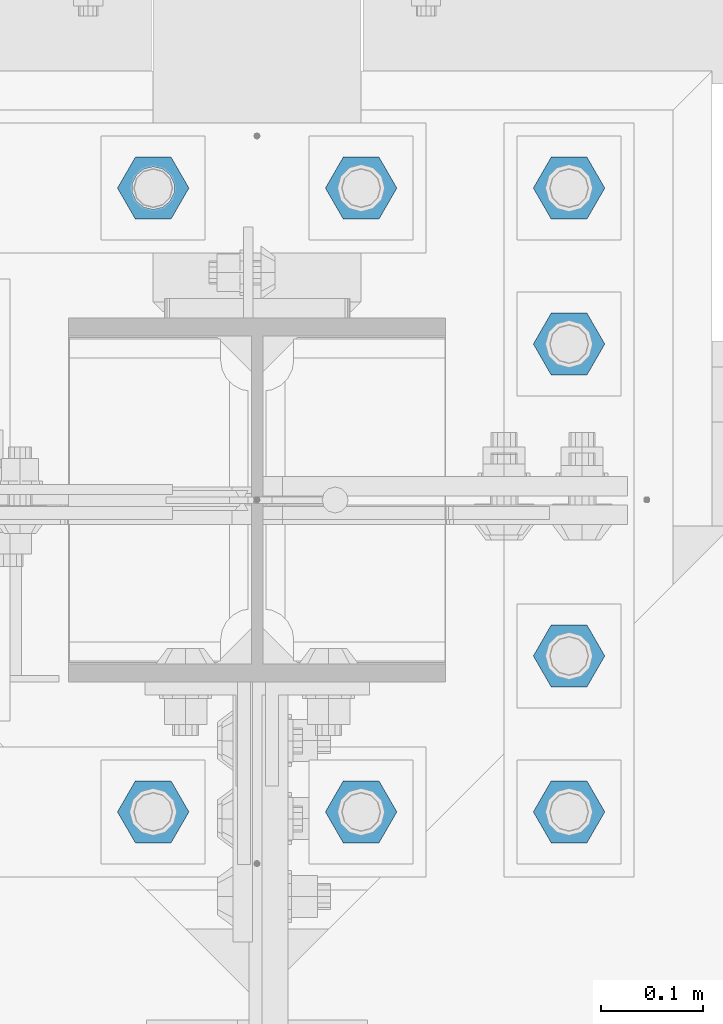
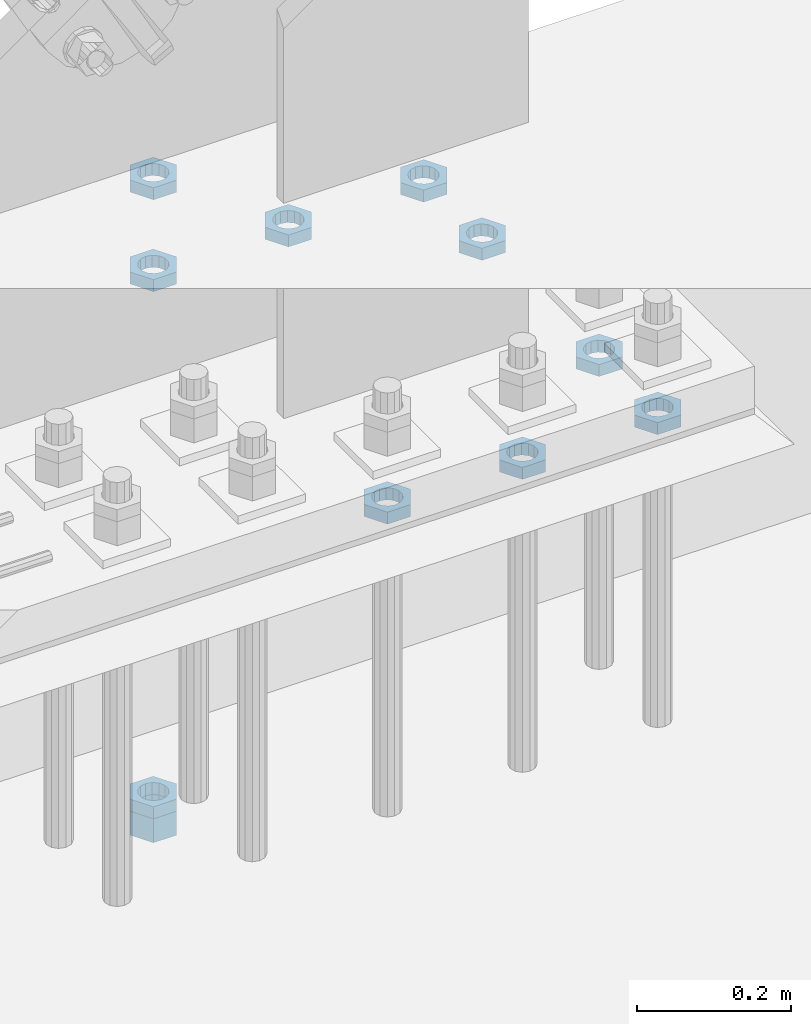
# One storey, part 2896 of 3843: 11 beams, 1 element without a shape of its own.
"""IFC2X3 building model written with IfcOpenShell, lengths in millimetres."""

from ifc_helpers import new_model, si_unit, frame, origin_with_axes, place, context, subcontext, project, spatial, faceted_brep, material, type_object, element, aggregate, save


model = new_model("IFC2X3")

# Units and contexts
model_context = context("Model", 3, precision=1e-05, world=origin_with_axes())
body_context = subcontext(model_context, "Body", "Model", "MODEL_VIEW")
ifc_project = project(units=[si_unit("LENGTHUNIT", "METRE", prefix="MILLI"), si_unit("AREAUNIT", "SQUARE_METRE"), si_unit("VOLUMEUNIT", "CUBIC_METRE"), si_unit("MASSUNIT", "GRAM", prefix="KILO"), si_unit("TIMEUNIT", "SECOND"), si_unit("PLANEANGLEUNIT", "RADIAN"), si_unit("SOLIDANGLEUNIT", "STERADIAN"), si_unit("THERMODYNAMICTEMPERATUREUNIT", "DEGREE_CELSIUS"), si_unit("LUMINOUSINTENSITYUNIT", "LUMEN")], contexts=[model_context])

# Site, building, storey
site_placement = place(None, origin_with_axes())
site = spatial("IfcSite", under=ifc_project, at=site_placement, CompositionType="ELEMENT")
building_placement = place(site_placement, origin_with_axes())
building = spatial("IfcBuilding", under=site, at=building_placement, Name="Undefined", CompositionType="ELEMENT")
storey_placement = place(building_placement, origin_with_axes())
storey = spatial("IfcBuildingStorey", under=building, at=storey_placement, Name="Undefined", CompositionType="ELEMENT", Elevation=0.0)

# Assembly, beams
assembly_placement = place(storey_placement, origin_with_axes())
assembly = element("IfcElementAssembly", 1, at=assembly_placement, inside=storey, Name="TEMPLATE", AssemblyPlace="NOTDEFINED", PredefinedType="RIGID_FRAME")
ifc_material = material(Name="STEEL/A572-50")
beam_type_1 = type_object("IfcBeamType", Name="1-1/2_HEAVY_HEX_NUT", PredefinedType="NOTDEFINED")
beam_1_placement = place(assembly_placement, frame((62534.8, 92519.5, 29203.6500015259), z_axis=(0.0, -1.0, 0.0), x_axis=(0.0, 0.0, -1.0)))
beam_1 = element("IfcBeam", 2, at=beam_1_placement, type_object=beam_type_1, material=ifc_material, Name="NUT", ObjectType="1-1/2_HEAVY_HEX_NUT", context=body_context, shape_type="Brep", body=[
    faceted_brep([(0.0, -34.9199981689453, 0.0), (0.0, -17.4599990844727, -30.25), (38.0999999999985, -17.4599990844727, -30.25), (38.0999999999985, -34.9199981689453, 0.0), (0.0, 17.4599990844727, -30.25), (38.0999999999985, 17.4599990844727, -30.25), (0.0, 34.9199981689453, 0.0), (38.0999999999985, 34.9199981689453, 0.0), (0.0, 17.4599990844727, 30.25), (38.0999999999985, 17.4599990844727, 30.25), (0.0, -17.4599990844727, 30.25), (38.0999999999985, -17.4599990844727, 30.25), (0.0, 0.0, 20.6399993896484), (0.0, 8.9553601105581, 18.5959968835959), (38.0999999999985, 8.9553601105581, 18.5959968835959), (38.0999999999985, 0.0, 20.6399993896484), (0.0, 16.1370013209525, 12.8688291298167), (38.0999999999985, 16.1370013209525, 12.8688291298167), (0.0, 20.1225115123816, 4.59283194104501), (38.0999999999985, 20.1225115123816, 4.59283194104501), (0.0, 20.1225115123816, -4.59283194104501), (38.0999999999985, 20.1225115123816, -4.59283194104501), (0.0, 16.1370013209525, -12.8688291298167), (38.0999999999985, 16.1370013209525, -12.8688291298167), (0.0, 8.9553601105581, -18.5959968835959), (38.0999999999985, 8.9553601105581, -18.5959968835959), (0.0, 0.0, -20.6399993896484), (38.0999999999985, 0.0, -20.6399993896484), (0.0, -8.9553601105581, -18.5959968835959), (38.0999999999985, -8.9553601105581, -18.5959968835959), (0.0, -16.1370013209525, -12.8688291298167), (38.0999999999985, -16.1370013209525, -12.8688291298167), (0.0, -20.1225115123816, -4.59283194104501), (38.0999999999985, -20.1225115123816, -4.59283194104501), (0.0, -20.1225115123816, 4.59283194104501), (38.0999999999985, -20.1225115123816, 4.59283194104501), (0.0, -16.1370013209525, 12.8688291298167), (38.0999999999985, -16.1370013209525, 12.8688291298167), (0.0, -8.9553601105581, 18.5959968835959), (38.0999999999985, -8.9553601105581, 18.5959968835959)], [[[0, 1, 2, 3]], [[1, 4, 5, 2]], [[4, 6, 7, 5]], [[6, 8, 9, 7]], [[8, 10, 11, 9]], [[10, 0, 3, 11]], [[12, 13, 14, 15]], [[13, 16, 17, 14]], [[16, 18, 19, 17]], [[18, 20, 21, 19]], [[20, 22, 23, 21]], [[22, 24, 25, 23]], [[24, 26, 27, 25]], [[26, 28, 29, 27]], [[28, 30, 31, 29]], [[30, 32, 33, 31]], [[32, 34, 35, 33]], [[34, 36, 37, 35]], [[36, 38, 39, 37]], [[38, 12, 15, 39]], [[5, 7, 9, 11, 3, 2], [17, 19, 21, 23, 25, 27, 29, 31, 33, 35, 37, 39, 15, 14]], [[10, 8, 6, 4, 1, 0], [38, 36, 34, 32, 30, 28, 26, 24, 22, 20, 18, 16, 13, 12]]]),
])
beam_type_2 = type_object("IfcBeamType", Name="1-1/2_HALF_NUT", PredefinedType="NOTDEFINED")
beam_2_placement = place(assembly_placement, frame((62534.8, 92519.5, 30060.9), z_axis=(0.0, -1.0, 0.0), x_axis=(0.0, 0.0, -1.0)))
beam_2 = element("IfcBeam", 3, at=beam_2_placement, type_object=beam_type_2, material=ifc_material, Name="NUT", ObjectType="1-1/2_HALF_NUT", context=body_context, shape_type="Brep", body=[
    faceted_brep([(0.0, -34.9199981689453, 0.0), (0.0, -17.4599990844727, -30.25), (19.0500000000029, -17.4599990844727, -30.25), (19.0500000000029, -34.9199981689453, 0.0), (0.0, 17.4599990844727, -30.25), (19.0500000000029, 17.4599990844727, -30.25), (0.0, 34.9199981689453, 0.0), (19.0500000000029, 34.9199981689453, 0.0), (0.0, 17.4599990844727, 30.25), (19.0500000000029, 17.4599990844727, 30.25), (0.0, -17.4599990844727, 30.25), (19.0500000000029, -17.4599990844727, 30.25), (0.0, 0.0, 20.6399993896484), (0.0, 8.9553601105581, 18.5959968835959), (19.0500000000029, 8.95536011056538, 18.5959968835959), (19.0500000000029, 0.0, 20.6399993896484), (0.0, 16.1370013209525, 12.8688291298167), (19.0500000000029, 16.1370013209489, 12.8688291298167), (0.0, 20.1225115123816, 4.59283194104501), (19.0500000000029, 20.1225115123852, 4.59283194104501), (0.0, 20.1225115123816, -4.59283194104501), (19.0500000000029, 20.1225115123852, -4.59283194104501), (0.0, 16.1370013209525, -12.8688291298167), (19.0500000000029, 16.1370013209489, -12.8688291298167), (0.0, 8.9553601105581, -18.5959968835959), (19.0500000000029, 8.95536011056538, -18.5959968835959), (0.0, 0.0, -20.6399993896484), (19.0500000000029, 0.0, -20.6399993896484), (0.0, -8.9553601105581, -18.5959968835959), (19.0500000000029, -8.95536011056538, -18.5959968835959), (0.0, -16.1370013209525, -12.8688291298167), (19.0500000000029, -16.1370013209489, -12.8688291298167), (0.0, -20.1225115123816, -4.59283194104501), (19.0500000000029, -20.1225115123852, -4.59283194104501), (0.0, -20.1225115123816, 4.59283194104501), (19.0500000000029, -20.1225115123852, 4.59283194104501), (0.0, -16.1370013209525, 12.8688291298167), (19.0500000000029, -16.1370013209489, 12.8688291298167), (0.0, -8.9553601105581, 18.5959968835959), (19.0500000000029, -8.95536011056538, 18.5959968835959)], [[[0, 1, 2, 3]], [[1, 4, 5, 2]], [[4, 6, 7, 5]], [[6, 8, 9, 7]], [[8, 10, 11, 9]], [[10, 0, 3, 11]], [[12, 13, 14, 15]], [[13, 16, 17, 14]], [[16, 18, 19, 17]], [[18, 20, 21, 19]], [[20, 22, 23, 21]], [[22, 24, 25, 23]], [[24, 26, 27, 25]], [[26, 28, 29, 27]], [[28, 30, 31, 29]], [[30, 32, 33, 31]], [[32, 34, 35, 33]], [[34, 36, 37, 35]], [[36, 38, 39, 37]], [[38, 12, 15, 39]], [[5, 7, 9, 11, 3, 2], [17, 19, 21, 23, 25, 27, 29, 31, 33, 35, 37, 39, 15, 14]], [[10, 8, 6, 4, 1, 0], [38, 36, 34, 32, 30, 28, 26, 24, 22, 20, 18, 16, 13, 12]]]),
])
beam_3_placement = place(assembly_placement, frame((62738.0, 92519.5, 30060.9), z_axis=(0.0, 1.0, 0.0), x_axis=(0.0, 0.0, -1.0)))
beam_3 = element("IfcBeam", 4, at=beam_3_placement, type_object=beam_type_2, material=ifc_material, Name="NUT", ObjectType="1-1/2_HALF_NUT", context=body_context, shape_type="Brep", body=[
    faceted_brep([(0.0, -34.9199981689453, 0.0), (0.0, -17.4599990844727, -30.25), (19.0500000000029, -17.4599990844727, -30.25), (19.0500000000029, -34.9199981689453, 0.0), (0.0, 17.4599990844727, -30.25), (19.0500000000029, 17.4599990844727, -30.25), (0.0, 34.9199981689453, 0.0), (19.0500000000029, 34.9199981689453, 0.0), (0.0, 17.4599990844727, 30.25), (19.0500000000029, 17.4599990844727, 30.25), (0.0, -17.4599990844727, 30.25), (19.0500000000029, -17.4599990844727, 30.25), (0.0, 0.0, 20.6399993896484), (0.0, 8.9553601105581, 18.5959968835959), (19.0500000000029, 8.95536011056538, 18.5959968835959), (19.0500000000029, 0.0, 20.6399993896484), (0.0, 16.1370013209525, 12.8688291298167), (19.0500000000029, 16.1370013209489, 12.8688291298167), (0.0, 20.1225115123816, 4.59283194104501), (19.0500000000029, 20.1225115123852, 4.59283194104501), (0.0, 20.1225115123816, -4.59283194104501), (19.0500000000029, 20.1225115123852, -4.59283194104501), (0.0, 16.1370013209525, -12.8688291298167), (19.0500000000029, 16.1370013209489, -12.8688291298167), (0.0, 8.9553601105581, -18.5959968835959), (19.0500000000029, 8.95536011056538, -18.5959968835959), (0.0, 0.0, -20.6399993896484), (19.0500000000029, 0.0, -20.6399993896484), (0.0, -8.9553601105581, -18.5959968835959), (19.0500000000029, -8.95536011056538, -18.5959968835959), (0.0, -16.1370013209525, -12.8688291298167), (19.0500000000029, -16.1370013209489, -12.8688291298167), (0.0, -20.1225115123816, -4.59283194104501), (19.0500000000029, -20.1225115123852, -4.59283194104501), (0.0, -20.1225115123816, 4.59283194104501), (19.0500000000029, -20.1225115123852, 4.59283194104501), (0.0, -16.1370013209525, 12.8688291298167), (19.0500000000029, -16.1370013209489, 12.8688291298167), (0.0, -8.9553601105581, 18.5959968835959), (19.0500000000029, -8.95536011056538, 18.5959968835959)], [[[0, 1, 2, 3]], [[1, 4, 5, 2]], [[4, 6, 7, 5]], [[6, 8, 9, 7]], [[8, 10, 11, 9]], [[10, 0, 3, 11]], [[12, 13, 14, 15]], [[13, 16, 17, 14]], [[16, 18, 19, 17]], [[18, 20, 21, 19]], [[20, 22, 23, 21]], [[22, 24, 25, 23]], [[24, 26, 27, 25]], [[26, 28, 29, 27]], [[28, 30, 31, 29]], [[30, 32, 33, 31]], [[32, 34, 35, 33]], [[34, 36, 37, 35]], [[36, 38, 39, 37]], [[38, 12, 15, 39]], [[5, 7, 9, 11, 3, 2], [17, 19, 21, 23, 25, 27, 29, 31, 33, 35, 37, 39, 15, 14]], [[10, 8, 6, 4, 1, 0], [38, 36, 34, 32, 30, 28, 26, 24, 22, 20, 18, 16, 13, 12]]]),
])
beam_4_placement = place(assembly_placement, frame((62534.8, 91909.9, 30060.9), z_axis=(0.0, -1.0, 0.0), x_axis=(0.0, 0.0, -1.0)))
beam_4 = element("IfcBeam", 5, at=beam_4_placement, type_object=beam_type_2, material=ifc_material, Name="NUT", ObjectType="1-1/2_HALF_NUT", context=body_context, shape_type="Brep", body=[
    faceted_brep([(0.0, -34.9199981689453, 0.0), (0.0, -17.4599990844727, -30.25), (19.0500000000029, -17.4599990844727, -30.25), (19.0500000000029, -34.9199981689453, 0.0), (0.0, 17.4599990844727, -30.25), (19.0500000000029, 17.4599990844727, -30.25), (0.0, 34.9199981689453, 0.0), (19.0500000000029, 34.9199981689453, 0.0), (0.0, 17.4599990844727, 30.25), (19.0500000000029, 17.4599990844727, 30.25), (0.0, -17.4599990844727, 30.25), (19.0500000000029, -17.4599990844727, 30.25), (0.0, 0.0, 20.6399993896484), (0.0, 8.9553601105581, 18.5959968835959), (19.0500000000029, 8.95536011056538, 18.5959968835959), (19.0500000000029, 0.0, 20.6399993896484), (0.0, 16.1370013209525, 12.8688291298167), (19.0500000000029, 16.1370013209489, 12.8688291298167), (0.0, 20.1225115123816, 4.59283194104501), (19.0500000000029, 20.1225115123852, 4.59283194104501), (0.0, 20.1225115123816, -4.59283194104501), (19.0500000000029, 20.1225115123852, -4.59283194104501), (0.0, 16.1370013209525, -12.8688291298167), (19.0500000000029, 16.1370013209489, -12.8688291298167), (0.0, 8.9553601105581, -18.5959968835959), (19.0500000000029, 8.95536011056538, -18.5959968835959), (0.0, 0.0, -20.6399993896484), (19.0500000000029, 0.0, -20.6399993896484), (0.0, -8.9553601105581, -18.5959968835959), (19.0500000000029, -8.95536011056538, -18.5959968835959), (0.0, -16.1370013209525, -12.8688291298167), (19.0500000000029, -16.1370013209489, -12.8688291298167), (0.0, -20.1225115123816, -4.59283194104501), (19.0500000000029, -20.1225115123852, -4.59283194104501), (0.0, -20.1225115123816, 4.59283194104501), (19.0500000000029, -20.1225115123852, 4.59283194104501), (0.0, -16.1370013209525, 12.8688291298167), (19.0500000000029, -16.1370013209489, 12.8688291298167), (0.0, -8.9553601105581, 18.5959968835959), (19.0500000000029, -8.95536011056538, 18.5959968835959)], [[[0, 1, 2, 3]], [[1, 4, 5, 2]], [[4, 6, 7, 5]], [[6, 8, 9, 7]], [[8, 10, 11, 9]], [[10, 0, 3, 11]], [[12, 13, 14, 15]], [[13, 16, 17, 14]], [[16, 18, 19, 17]], [[18, 20, 21, 19]], [[20, 22, 23, 21]], [[22, 24, 25, 23]], [[24, 26, 27, 25]], [[26, 28, 29, 27]], [[28, 30, 31, 29]], [[30, 32, 33, 31]], [[32, 34, 35, 33]], [[34, 36, 37, 35]], [[36, 38, 39, 37]], [[38, 12, 15, 39]], [[5, 7, 9, 11, 3, 2], [17, 19, 21, 23, 25, 27, 29, 31, 33, 35, 37, 39, 15, 14]], [[10, 8, 6, 4, 1, 0], [38, 36, 34, 32, 30, 28, 26, 24, 22, 20, 18, 16, 13, 12]]]),
])
beam_5_placement = place(assembly_placement, frame((62941.2, 92519.5, 30060.9), z_axis=(0.0, 1.0, 0.0), x_axis=(0.0, 0.0, -1.0)))
beam_5 = element("IfcBeam", 6, at=beam_5_placement, type_object=beam_type_2, material=ifc_material, Name="NUT", ObjectType="1-1/2_HALF_NUT", context=body_context, shape_type="Brep", body=[
    faceted_brep([(0.0, -34.9199981689453, 0.0), (0.0, -17.4599990844727, -30.25), (19.0500000000029, -17.4599990844727, -30.25), (19.0500000000029, -34.9199981689453, 0.0), (0.0, 17.4599990844727, -30.25), (19.0500000000029, 17.4599990844727, -30.25), (0.0, 34.9199981689453, 0.0), (19.0500000000029, 34.9199981689453, 0.0), (0.0, 17.4599990844727, 30.25), (19.0500000000029, 17.4599990844727, 30.25), (0.0, -17.4599990844727, 30.25), (19.0500000000029, -17.4599990844727, 30.25), (0.0, 0.0, 20.6399993896484), (0.0, 8.9553601105581, 18.5959968835959), (19.0500000000029, 8.95536011056538, 18.5959968835959), (19.0500000000029, 0.0, 20.6399993896484), (0.0, 16.1370013209525, 12.8688291298167), (19.0500000000029, 16.1370013209489, 12.8688291298167), (0.0, 20.1225115123816, 4.59283194104501), (19.0500000000029, 20.1225115123852, 4.59283194104501), (0.0, 20.1225115123816, -4.59283194104501), (19.0500000000029, 20.1225115123852, -4.59283194104501), (0.0, 16.1370013209525, -12.8688291298167), (19.0500000000029, 16.1370013209489, -12.8688291298167), (0.0, 8.9553601105581, -18.5959968835959), (19.0500000000029, 8.95536011056538, -18.5959968835959), (0.0, 0.0, -20.6399993896484), (19.0500000000029, 0.0, -20.6399993896484), (0.0, -8.9553601105581, -18.5959968835959), (19.0500000000029, -8.95536011056538, -18.5959968835959), (0.0, -16.1370013209525, -12.8688291298167), (19.0500000000029, -16.1370013209489, -12.8688291298167), (0.0, -20.1225115123816, -4.59283194104501), (19.0500000000029, -20.1225115123852, -4.59283194104501), (0.0, -20.1225115123816, 4.59283194104501), (19.0500000000029, -20.1225115123852, 4.59283194104501), (0.0, -16.1370013209525, 12.8688291298167), (19.0500000000029, -16.1370013209489, 12.8688291298167), (0.0, -8.9553601105581, 18.5959968835959), (19.0500000000029, -8.95536011056538, 18.5959968835959)], [[[0, 1, 2, 3]], [[1, 4, 5, 2]], [[4, 6, 7, 5]], [[6, 8, 9, 7]], [[8, 10, 11, 9]], [[10, 0, 3, 11]], [[12, 13, 14, 15]], [[13, 16, 17, 14]], [[16, 18, 19, 17]], [[18, 20, 21, 19]], [[20, 22, 23, 21]], [[22, 24, 25, 23]], [[24, 26, 27, 25]], [[26, 28, 29, 27]], [[28, 30, 31, 29]], [[30, 32, 33, 31]], [[32, 34, 35, 33]], [[34, 36, 37, 35]], [[36, 38, 39, 37]], [[38, 12, 15, 39]], [[5, 7, 9, 11, 3, 2], [17, 19, 21, 23, 25, 27, 29, 31, 33, 35, 37, 39, 15, 14]], [[10, 8, 6, 4, 1, 0], [38, 36, 34, 32, 30, 28, 26, 24, 22, 20, 18, 16, 13, 12]]]),
])
beam_6_placement = place(assembly_placement, frame((62941.2, 92367.1, 30060.9), z_axis=(0.0, 1.0, 0.0), x_axis=(0.0, 0.0, -1.0)))
beam_6 = element("IfcBeam", 7, at=beam_6_placement, type_object=beam_type_2, material=ifc_material, Name="NUT", ObjectType="1-1/2_HALF_NUT", context=body_context, shape_type="Brep", body=[
    faceted_brep([(0.0, -34.9199981689453, 0.0), (0.0, -17.4599990844727, -30.25), (19.0500000000029, -17.4599990844727, -30.25), (19.0500000000029, -34.9199981689453, 0.0), (0.0, 17.4599990844727, -30.25), (19.0500000000029, 17.4599990844727, -30.25), (0.0, 34.9199981689453, 0.0), (19.0500000000029, 34.9199981689453, 0.0), (0.0, 17.4599990844727, 30.25), (19.0500000000029, 17.4599990844727, 30.25), (0.0, -17.4599990844727, 30.25), (19.0500000000029, -17.4599990844727, 30.25), (0.0, 0.0, 20.6399993896484), (0.0, 8.9553601105581, 18.5959968835959), (19.0500000000029, 8.95536011056538, 18.5959968835959), (19.0500000000029, 0.0, 20.6399993896484), (0.0, 16.1370013209525, 12.8688291298167), (19.0500000000029, 16.1370013209489, 12.8688291298167), (0.0, 20.1225115123816, 4.59283194104501), (19.0500000000029, 20.1225115123852, 4.59283194104501), (0.0, 20.1225115123816, -4.59283194104501), (19.0500000000029, 20.1225115123852, -4.59283194104501), (0.0, 16.1370013209525, -12.8688291298167), (19.0500000000029, 16.1370013209489, -12.8688291298167), (0.0, 8.9553601105581, -18.5959968835959), (19.0500000000029, 8.95536011056538, -18.5959968835959), (0.0, 0.0, -20.6399993896484), (19.0500000000029, 0.0, -20.6399993896484), (0.0, -8.9553601105581, -18.5959968835959), (19.0500000000029, -8.95536011056538, -18.5959968835959), (0.0, -16.1370013209525, -12.8688291298167), (19.0500000000029, -16.1370013209489, -12.8688291298167), (0.0, -20.1225115123816, -4.59283194104501), (19.0500000000029, -20.1225115123852, -4.59283194104501), (0.0, -20.1225115123816, 4.59283194104501), (19.0500000000029, -20.1225115123852, 4.59283194104501), (0.0, -16.1370013209525, 12.8688291298167), (19.0500000000029, -16.1370013209489, 12.8688291298167), (0.0, -8.9553601105581, 18.5959968835959), (19.0500000000029, -8.95536011056538, 18.5959968835959)], [[[0, 1, 2, 3]], [[1, 4, 5, 2]], [[4, 6, 7, 5]], [[6, 8, 9, 7]], [[8, 10, 11, 9]], [[10, 0, 3, 11]], [[12, 13, 14, 15]], [[13, 16, 17, 14]], [[16, 18, 19, 17]], [[18, 20, 21, 19]], [[20, 22, 23, 21]], [[22, 24, 25, 23]], [[24, 26, 27, 25]], [[26, 28, 29, 27]], [[28, 30, 31, 29]], [[30, 32, 33, 31]], [[32, 34, 35, 33]], [[34, 36, 37, 35]], [[36, 38, 39, 37]], [[38, 12, 15, 39]], [[5, 7, 9, 11, 3, 2], [17, 19, 21, 23, 25, 27, 29, 31, 33, 35, 37, 39, 15, 14]], [[10, 8, 6, 4, 1, 0], [38, 36, 34, 32, 30, 28, 26, 24, 22, 20, 18, 16, 13, 12]]]),
])
beam_7_placement = place(assembly_placement, frame((62738.0, 91909.9, 30060.9), z_axis=(0.0, 1.0, 0.0), x_axis=(0.0, 0.0, -1.0)))
beam_7 = element("IfcBeam", 8, at=beam_7_placement, type_object=beam_type_2, material=ifc_material, Name="NUT", ObjectType="1-1/2_HALF_NUT", context=body_context, shape_type="Brep", body=[
    faceted_brep([(0.0, -34.9199981689453, 0.0), (0.0, -17.4599990844727, -30.25), (19.0500000000029, -17.4599990844727, -30.25), (19.0500000000029, -34.9199981689453, 0.0), (0.0, 17.4599990844727, -30.25), (19.0500000000029, 17.4599990844727, -30.25), (0.0, 34.9199981689453, 0.0), (19.0500000000029, 34.9199981689453, 0.0), (0.0, 17.4599990844727, 30.25), (19.0500000000029, 17.4599990844727, 30.25), (0.0, -17.4599990844727, 30.25), (19.0500000000029, -17.4599990844727, 30.25), (0.0, 0.0, 20.6399993896484), (0.0, 8.9553601105581, 18.5959968835959), (19.0500000000029, 8.95536011056538, 18.5959968835959), (19.0500000000029, 0.0, 20.6399993896484), (0.0, 16.1370013209525, 12.8688291298167), (19.0500000000029, 16.1370013209489, 12.8688291298167), (0.0, 20.1225115123816, 4.59283194104501), (19.0500000000029, 20.1225115123852, 4.59283194104501), (0.0, 20.1225115123816, -4.59283194104501), (19.0500000000029, 20.1225115123852, -4.59283194104501), (0.0, 16.1370013209525, -12.8688291298167), (19.0500000000029, 16.1370013209489, -12.8688291298167), (0.0, 8.9553601105581, -18.5959968835959), (19.0500000000029, 8.95536011056538, -18.5959968835959), (0.0, 0.0, -20.6399993896484), (19.0500000000029, 0.0, -20.6399993896484), (0.0, -8.9553601105581, -18.5959968835959), (19.0500000000029, -8.95536011056538, -18.5959968835959), (0.0, -16.1370013209525, -12.8688291298167), (19.0500000000029, -16.1370013209489, -12.8688291298167), (0.0, -20.1225115123816, -4.59283194104501), (19.0500000000029, -20.1225115123852, -4.59283194104501), (0.0, -20.1225115123816, 4.59283194104501), (19.0500000000029, -20.1225115123852, 4.59283194104501), (0.0, -16.1370013209525, 12.8688291298167), (19.0500000000029, -16.1370013209489, 12.8688291298167), (0.0, -8.9553601105581, 18.5959968835959), (19.0500000000029, -8.95536011056538, 18.5959968835959)], [[[0, 1, 2, 3]], [[1, 4, 5, 2]], [[4, 6, 7, 5]], [[6, 8, 9, 7]], [[8, 10, 11, 9]], [[10, 0, 3, 11]], [[12, 13, 14, 15]], [[13, 16, 17, 14]], [[16, 18, 19, 17]], [[18, 20, 21, 19]], [[20, 22, 23, 21]], [[22, 24, 25, 23]], [[24, 26, 27, 25]], [[26, 28, 29, 27]], [[28, 30, 31, 29]], [[30, 32, 33, 31]], [[32, 34, 35, 33]], [[34, 36, 37, 35]], [[36, 38, 39, 37]], [[38, 12, 15, 39]], [[5, 7, 9, 11, 3, 2], [17, 19, 21, 23, 25, 27, 29, 31, 33, 35, 37, 39, 15, 14]], [[10, 8, 6, 4, 1, 0], [38, 36, 34, 32, 30, 28, 26, 24, 22, 20, 18, 16, 13, 12]]]),
])
beam_8_placement = place(assembly_placement, frame((62941.2, 92062.3, 30060.9), z_axis=(0.0, 1.0, 0.0), x_axis=(0.0, 0.0, -1.0)))
beam_8 = element("IfcBeam", 9, at=beam_8_placement, type_object=beam_type_2, material=ifc_material, Name="NUT", ObjectType="1-1/2_HALF_NUT", context=body_context, shape_type="Brep", body=[
    faceted_brep([(0.0, -34.9199981689453, 0.0), (0.0, -17.4599990844727, -30.25), (19.0500000000029, -17.4599990844727, -30.25), (19.0500000000029, -34.9199981689453, 0.0), (0.0, 17.4599990844727, -30.25), (19.0500000000029, 17.4599990844727, -30.25), (0.0, 34.9199981689453, 0.0), (19.0500000000029, 34.9199981689453, 0.0), (0.0, 17.4599990844727, 30.25), (19.0500000000029, 17.4599990844727, 30.25), (0.0, -17.4599990844727, 30.25), (19.0500000000029, -17.4599990844727, 30.25), (0.0, 0.0, 20.6399993896484), (0.0, 8.9553601105581, 18.5959968835959), (19.0500000000029, 8.95536011056538, 18.5959968835959), (19.0500000000029, 0.0, 20.6399993896484), (0.0, 16.1370013209525, 12.8688291298167), (19.0500000000029, 16.1370013209489, 12.8688291298167), (0.0, 20.1225115123816, 4.59283194104501), (19.0500000000029, 20.1225115123852, 4.59283194104501), (0.0, 20.1225115123816, -4.59283194104501), (19.0500000000029, 20.1225115123852, -4.59283194104501), (0.0, 16.1370013209525, -12.8688291298167), (19.0500000000029, 16.1370013209489, -12.8688291298167), (0.0, 8.9553601105581, -18.5959968835959), (19.0500000000029, 8.95536011056538, -18.5959968835959), (0.0, 0.0, -20.6399993896484), (19.0500000000029, 0.0, -20.6399993896484), (0.0, -8.9553601105581, -18.5959968835959), (19.0500000000029, -8.95536011056538, -18.5959968835959), (0.0, -16.1370013209525, -12.8688291298167), (19.0500000000029, -16.1370013209489, -12.8688291298167), (0.0, -20.1225115123816, -4.59283194104501), (19.0500000000029, -20.1225115123852, -4.59283194104501), (0.0, -20.1225115123816, 4.59283194104501), (19.0500000000029, -20.1225115123852, 4.59283194104501), (0.0, -16.1370013209525, 12.8688291298167), (19.0500000000029, -16.1370013209489, 12.8688291298167), (0.0, -8.9553601105581, 18.5959968835959), (19.0500000000029, -8.95536011056538, 18.5959968835959)], [[[0, 1, 2, 3]], [[1, 4, 5, 2]], [[4, 6, 7, 5]], [[6, 8, 9, 7]], [[8, 10, 11, 9]], [[10, 0, 3, 11]], [[12, 13, 14, 15]], [[13, 16, 17, 14]], [[16, 18, 19, 17]], [[18, 20, 21, 19]], [[20, 22, 23, 21]], [[22, 24, 25, 23]], [[24, 26, 27, 25]], [[26, 28, 29, 27]], [[28, 30, 31, 29]], [[30, 32, 33, 31]], [[32, 34, 35, 33]], [[34, 36, 37, 35]], [[36, 38, 39, 37]], [[38, 12, 15, 39]], [[5, 7, 9, 11, 3, 2], [17, 19, 21, 23, 25, 27, 29, 31, 33, 35, 37, 39, 15, 14]], [[10, 8, 6, 4, 1, 0], [38, 36, 34, 32, 30, 28, 26, 24, 22, 20, 18, 16, 13, 12]]]),
])
beam_9_placement = place(assembly_placement, frame((62941.2, 91909.9, 30060.9), z_axis=(0.0, 1.0, 0.0), x_axis=(0.0, 0.0, -1.0)))
beam_9 = element("IfcBeam", 10, at=beam_9_placement, type_object=beam_type_2, material=ifc_material, Name="NUT", ObjectType="1-1/2_HALF_NUT", context=body_context, shape_type="Brep", body=[
    faceted_brep([(0.0, -34.9199981689453, 0.0), (0.0, -17.4599990844727, -30.25), (19.0500000000029, -17.4599990844727, -30.25), (19.0500000000029, -34.9199981689453, 0.0), (0.0, 17.4599990844727, -30.25), (19.0500000000029, 17.4599990844727, -30.25), (0.0, 34.9199981689453, 0.0), (19.0500000000029, 34.9199981689453, 0.0), (0.0, 17.4599990844727, 30.25), (19.0500000000029, 17.4599990844727, 30.25), (0.0, -17.4599990844727, 30.25), (19.0500000000029, -17.4599990844727, 30.25), (0.0, 0.0, 20.6399993896484), (0.0, 8.9553601105581, 18.5959968835959), (19.0500000000029, 8.95536011056538, 18.5959968835959), (19.0500000000029, 0.0, 20.6399993896484), (0.0, 16.1370013209525, 12.8688291298167), (19.0500000000029, 16.1370013209489, 12.8688291298167), (0.0, 20.1225115123816, 4.59283194104501), (19.0500000000029, 20.1225115123852, 4.59283194104501), (0.0, 20.1225115123816, -4.59283194104501), (19.0500000000029, 20.1225115123852, -4.59283194104501), (0.0, 16.1370013209525, -12.8688291298167), (19.0500000000029, 16.1370013209489, -12.8688291298167), (0.0, 8.9553601105581, -18.5959968835959), (19.0500000000029, 8.95536011056538, -18.5959968835959), (0.0, 0.0, -20.6399993896484), (19.0500000000029, 0.0, -20.6399993896484), (0.0, -8.9553601105581, -18.5959968835959), (19.0500000000029, -8.95536011056538, -18.5959968835959), (0.0, -16.1370013209525, -12.8688291298167), (19.0500000000029, -16.1370013209489, -12.8688291298167), (0.0, -20.1225115123816, -4.59283194104501), (19.0500000000029, -20.1225115123852, -4.59283194104501), (0.0, -20.1225115123816, 4.59283194104501), (19.0500000000029, -20.1225115123852, 4.59283194104501), (0.0, -16.1370013209525, 12.8688291298167), (19.0500000000029, -16.1370013209489, 12.8688291298167), (0.0, -8.9553601105581, 18.5959968835959), (19.0500000000029, -8.95536011056538, 18.5959968835959)], [[[0, 1, 2, 3]], [[1, 4, 5, 2]], [[4, 6, 7, 5]], [[6, 8, 9, 7]], [[8, 10, 11, 9]], [[10, 0, 3, 11]], [[12, 13, 14, 15]], [[13, 16, 17, 14]], [[16, 18, 19, 17]], [[18, 20, 21, 19]], [[20, 22, 23, 21]], [[22, 24, 25, 23]], [[24, 26, 27, 25]], [[26, 28, 29, 27]], [[28, 30, 31, 29]], [[30, 32, 33, 31]], [[32, 34, 35, 33]], [[34, 36, 37, 35]], [[36, 38, 39, 37]], [[38, 12, 15, 39]], [[5, 7, 9, 11, 3, 2], [17, 19, 21, 23, 25, 27, 29, 31, 33, 35, 37, 39, 15, 14]], [[10, 8, 6, 4, 1, 0], [38, 36, 34, 32, 30, 28, 26, 24, 22, 20, 18, 16, 13, 12]]]),
])
beam_10_placement = place(assembly_placement, frame((62534.8, 92519.5, 29222.7000015259), z_axis=(0.0, -1.0, 0.0), x_axis=(0.0, 0.0, -1.0)))
beam_10 = element("IfcBeam", 11, at=beam_10_placement, type_object=beam_type_2, material=ifc_material, Name="NUT", ObjectType="1-1/2_HALF_NUT", context=body_context, shape_type="Brep", body=[
    faceted_brep([(0.0, -34.9199981689453, 0.0), (0.0, -17.4599990844727, -30.25), (19.0500000000029, -17.4599990844727, -30.25), (19.0500000000029, -34.9199981689453, 0.0), (0.0, 17.4599990844727, -30.25), (19.0500000000029, 17.4599990844727, -30.25), (0.0, 34.9199981689453, 0.0), (19.0500000000029, 34.9199981689453, 0.0), (0.0, 17.4599990844727, 30.25), (19.0500000000029, 17.4599990844727, 30.25), (0.0, -17.4599990844727, 30.25), (19.0500000000029, -17.4599990844727, 30.25), (0.0, 0.0, 20.6399993896484), (0.0, 8.9553601105581, 18.5959968835959), (19.0500000000029, 8.95536011056538, 18.5959968835959), (19.0500000000029, 0.0, 20.6399993896484), (0.0, 16.1370013209525, 12.8688291298167), (19.0500000000029, 16.1370013209489, 12.8688291298167), (0.0, 20.1225115123816, 4.59283194104501), (19.0500000000029, 20.1225115123852, 4.59283194104501), (0.0, 20.1225115123816, -4.59283194104501), (19.0500000000029, 20.1225115123852, -4.59283194104501), (0.0, 16.1370013209525, -12.8688291298167), (19.0500000000029, 16.1370013209489, -12.8688291298167), (0.0, 8.9553601105581, -18.5959968835959), (19.0500000000029, 8.95536011056538, -18.5959968835959), (0.0, 0.0, -20.6399993896484), (19.0500000000029, 0.0, -20.6399993896484), (0.0, -8.9553601105581, -18.5959968835959), (19.0500000000029, -8.95536011056538, -18.5959968835959), (0.0, -16.1370013209525, -12.8688291298167), (19.0500000000029, -16.1370013209489, -12.8688291298167), (0.0, -20.1225115123816, -4.59283194104501), (19.0500000000029, -20.1225115123852, -4.59283194104501), (0.0, -20.1225115123816, 4.59283194104501), (19.0500000000029, -20.1225115123852, 4.59283194104501), (0.0, -16.1370013209525, 12.8688291298167), (19.0500000000029, -16.1370013209489, 12.8688291298167), (0.0, -8.9553601105581, 18.5959968835959), (19.0500000000029, -8.95536011056538, 18.5959968835959)], [[[0, 1, 2, 3]], [[1, 4, 5, 2]], [[4, 6, 7, 5]], [[6, 8, 9, 7]], [[8, 10, 11, 9]], [[10, 0, 3, 11]], [[12, 13, 14, 15]], [[13, 16, 17, 14]], [[16, 18, 19, 17]], [[18, 20, 21, 19]], [[20, 22, 23, 21]], [[22, 24, 25, 23]], [[24, 26, 27, 25]], [[26, 28, 29, 27]], [[28, 30, 31, 29]], [[30, 32, 33, 31]], [[32, 34, 35, 33]], [[34, 36, 37, 35]], [[36, 38, 39, 37]], [[38, 12, 15, 39]], [[5, 7, 9, 11, 3, 2], [17, 19, 21, 23, 25, 27, 29, 31, 33, 35, 37, 39, 15, 14]], [[10, 8, 6, 4, 1, 0], [38, 36, 34, 32, 30, 28, 26, 24, 22, 20, 18, 16, 13, 12]]]),
])
beam_11_placement = place(assembly_placement, frame((62534.800012207, 92519.5, 30206.95), z_axis=(0.0, -1.0, 0.0), x_axis=(0.0, 0.0, -1.0)))
beam_11 = element("IfcBeam", 12, at=beam_11_placement, type_object=beam_type_2, material=ifc_material, Name="NUT", ObjectType="1-1/2_HALF_NUT", context=body_context, shape_type="Brep", body=[
    faceted_brep([(0.0, -34.9199981689453, 0.0), (0.0, -17.4599990844727, -30.25), (19.0500000000029, -17.4599990844727, -30.25), (19.0500000000029, -34.9199981689453, 0.0), (0.0, 17.4599990844727, -30.25), (19.0500000000029, 17.4599990844727, -30.25), (0.0, 34.9199981689453, 0.0), (19.0500000000029, 34.9199981689453, 0.0), (0.0, 17.4599990844727, 30.25), (19.0500000000029, 17.4599990844727, 30.25), (0.0, -17.4599990844727, 30.25), (19.0500000000029, -17.4599990844727, 30.25), (0.0, 0.0, 20.6399993896484), (0.0, 8.9553601105581, 18.5959968835959), (19.0500000000029, 8.95536011056538, 18.5959968835959), (19.0500000000029, 0.0, 20.6399993896484), (0.0, 16.1370013209525, 12.8688291298167), (19.0500000000029, 16.1370013209489, 12.8688291298167), (0.0, 20.1225115123816, 4.59283194104501), (19.0500000000029, 20.1225115123852, 4.59283194104501), (0.0, 20.1225115123816, -4.59283194104501), (19.0500000000029, 20.1225115123852, -4.59283194104501), (0.0, 16.1370013209525, -12.8688291298167), (19.0500000000029, 16.1370013209489, -12.8688291298167), (0.0, 8.9553601105581, -18.5959968835959), (19.0500000000029, 8.95536011056538, -18.5959968835959), (0.0, 0.0, -20.6399993896484), (19.0500000000029, 0.0, -20.6399993896484), (0.0, -8.9553601105581, -18.5959968835959), (19.0500000000029, -8.95536011056538, -18.5959968835959), (0.0, -16.1370013209525, -12.8688291298167), (19.0500000000029, -16.1370013209489, -12.8688291298167), (0.0, -20.1225115123816, -4.59283194104501), (19.0500000000029, -20.1225115123852, -4.59283194104501), (0.0, -20.1225115123816, 4.59283194104501), (19.0500000000029, -20.1225115123852, 4.59283194104501), (0.0, -16.1370013209525, 12.8688291298167), (19.0500000000029, -16.1370013209489, 12.8688291298167), (0.0, -8.9553601105581, 18.5959968835959), (19.0500000000029, -8.95536011056538, 18.5959968835959)], [[[0, 1, 2, 3]], [[1, 4, 5, 2]], [[4, 6, 7, 5]], [[6, 8, 9, 7]], [[8, 10, 11, 9]], [[10, 0, 3, 11]], [[12, 13, 14, 15]], [[13, 16, 17, 14]], [[16, 18, 19, 17]], [[18, 20, 21, 19]], [[20, 22, 23, 21]], [[22, 24, 25, 23]], [[24, 26, 27, 25]], [[26, 28, 29, 27]], [[28, 30, 31, 29]], [[30, 32, 33, 31]], [[32, 34, 35, 33]], [[34, 36, 37, 35]], [[36, 38, 39, 37]], [[38, 12, 15, 39]], [[5, 7, 9, 11, 3, 2], [17, 19, 21, 23, 25, 27, 29, 31, 33, 35, 37, 39, 15, 14]], [[10, 8, 6, 4, 1, 0], [38, 36, 34, 32, 30, 28, 26, 24, 22, 20, 18, 16, 13, 12]]]),
])
aggregate(assembly, [beam_2, beam_3, beam_4, beam_5, beam_6, beam_7, beam_8, beam_9, beam_10, beam_1, beam_11])

save(model, "model.ifc")
